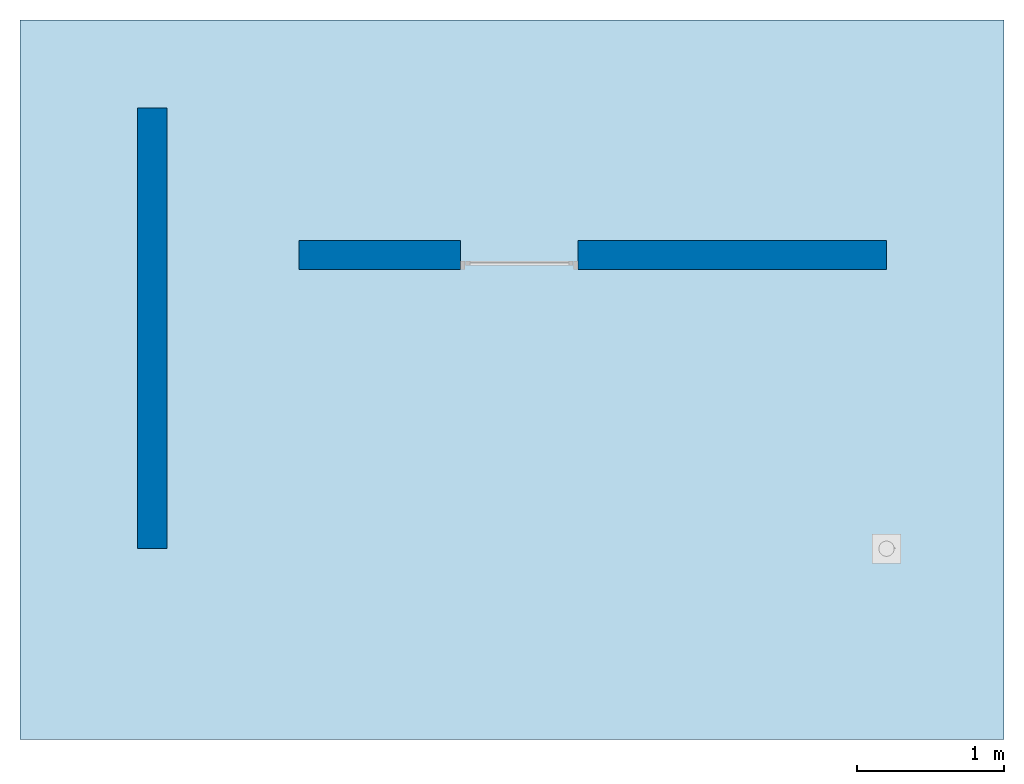
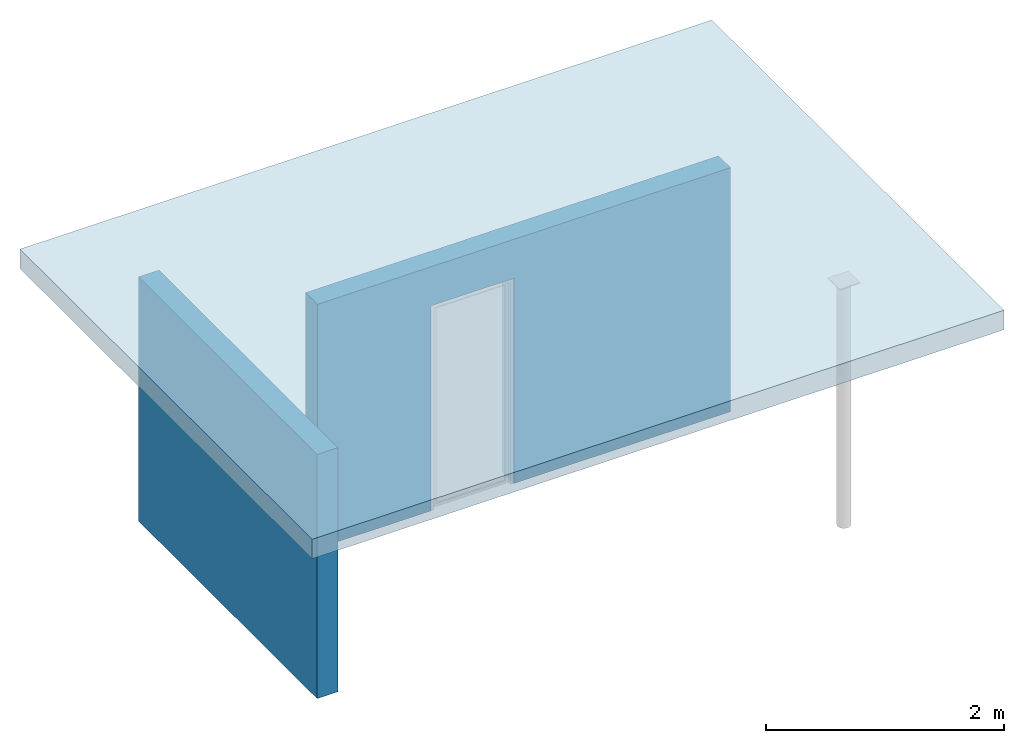
# Not in any storey, part 1 of 3: 2 walls, 1 slab, 1 opening.
"""IFC4 model written with IfcOpenShell, lengths in metres."""

from ifc_helpers import new_model, entity, si_unit, converted_unit, direction, frame, origin_with_axes, place, context, project, polyline, outline, extrude, faceted_brep, element, save


model = new_model("IFC4")

# Units and contexts
model_context = context("Model", 3, precision=1e-05, world=origin_with_axes(), true_north=direction((0.0, 1.0, 0.0)))
ifc_project = project(units=[si_unit("LENGTHUNIT", "METRE"), si_unit("AREAUNIT", "SQUARE_METRE"), si_unit("VOLUMEUNIT", "CUBIC_METRE"), converted_unit("PLANEANGLEUNIT", "DEGREE", entity("IfcPlaneAngleMeasure", 0.017453292519943295), si_unit("PLANEANGLEUNIT", "RADIAN"), dimensions=[0, 0, 0, 0, 0, 0, 0])], contexts=[model_context])

# Slab
placement = place(None, origin_with_axes())
element("IfcSlab", 1, at=placement, Name="Structure", PredefinedType="FLOOR", context=model_context, shape_type="SweptSolid", body=[
    extrude(outline(polyline([(3.35, -2.45), (3.35, 2.45), (-3.35, 2.45), (-3.35, -2.45), (3.35, -2.45)])), frame((2.45, 1.15, 2.5), z_axis=(0.0, 0.0, 1.0), x_axis=(1.0, 0.0, 0.0)), (0.0, 0.0, 1.0), 0.2),
])

# Wall
element("IfcWall", 2, at=placement, Name="Wall", PredefinedType="MOVABLE", context=model_context, shape_type="SweptSolid", body=[
    extrude(outline(polyline([(-0.1, 1.5), (-0.1, -1.5), (0.1, -1.5), (0.1, 1.5), (-0.1, 1.5)])), frame((-3.88578058618805e-19, 1.5, 0.0), z_axis=(0.0, 0.0, 1.0), x_axis=(1.0, 0.0, 0.0)), (0.0, 0.0, 1.0), 2.5),
])

# Wall, opening
wall_2 = element("IfcWall", 3, at=placement, Name="Wall001", PredefinedType="MOVABLE", context=model_context, shape_type="SweptSolid", body=[
    extrude(outline(polyline([(2.0, 0.0999999999999545), (-2.0, 0.1), (-2.0, -0.0999999999999545), (2.0, -0.1), (2.0, 0.0999999999999545)])), frame((3.0, 2.0, 0.0), z_axis=(0.0, 0.0, 1.0), x_axis=(1.0, 0.0, 0.0)), (0.0, 0.0, 1.0), 2.5),
])
element("IfcOpeningElement", 4, at=placement, cuts=wall_2, Name="Door", context=model_context, shape_type="Brep", body=[
    faceted_brep([(2.9, 4.0, -4.2e-16), (2.9, -0.2, 4.2e-16), (2.1, -0.2, 4.2e-16), (2.1, 4.0, -4.2e-16), (2.9, 4.0, 2.1), (2.9, -0.2, 2.1), (2.1, 4.0, 2.1), (2.1, -0.2, 2.1)], [[[0, 1, 2, 3]], [[4, 5, 1, 0]], [[6, 7, 5, 4]], [[3, 2, 7, 6]], [[6, 4, 0, 3]], [[2, 1, 5, 7]]]),
])

save(model, "model.ifc")
